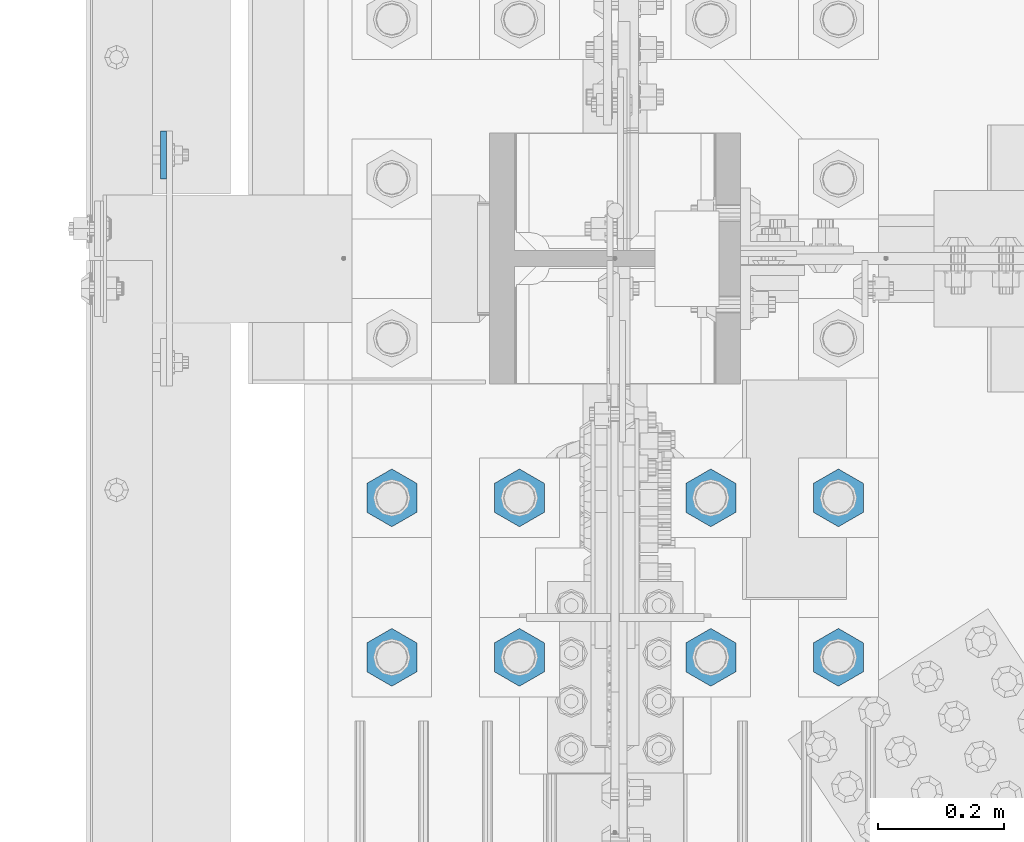
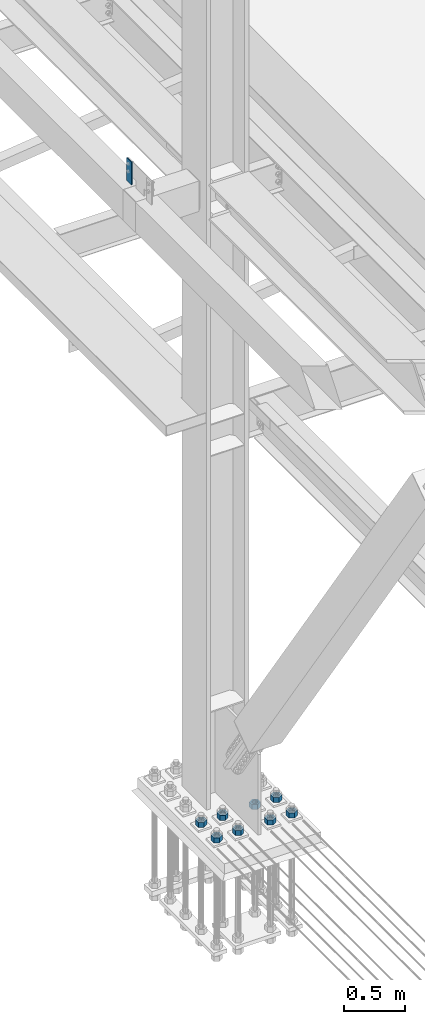
# One storey, part 1525 of 3843: 9 columns, 2 elements without a shape of their own.
"""IFC2X3 building model written with IfcOpenShell, lengths in millimetres."""

from ifc_helpers import new_model, si_unit, frame, origin_with_axes, place, context, subcontext, project, spatial, faceted_brep, material, type_object, element, aggregate, save


model = new_model("IFC2X3")

# Units and contexts
model_context = context("Model", 3, precision=1e-05, world=origin_with_axes())
body_context = subcontext(model_context, "Body", "Model", "MODEL_VIEW")
ifc_project = project(units=[si_unit("LENGTHUNIT", "METRE", prefix="MILLI"), si_unit("AREAUNIT", "SQUARE_METRE"), si_unit("VOLUMEUNIT", "CUBIC_METRE"), si_unit("MASSUNIT", "GRAM", prefix="KILO"), si_unit("TIMEUNIT", "SECOND"), si_unit("PLANEANGLEUNIT", "RADIAN"), si_unit("SOLIDANGLEUNIT", "STERADIAN"), si_unit("THERMODYNAMICTEMPERATUREUNIT", "DEGREE_CELSIUS"), si_unit("LUMINOUSINTENSITYUNIT", "LUMEN")], contexts=[model_context])

# Site, building, storey
site_placement = place(None, origin_with_axes())
site = spatial("IfcSite", under=ifc_project, at=site_placement, CompositionType="ELEMENT")
building_placement = place(site_placement, origin_with_axes())
building = spatial("IfcBuilding", under=site, at=building_placement, Name="Undefined", CompositionType="ELEMENT")
storey_placement = place(building_placement, origin_with_axes())
storey = spatial("IfcBuildingStorey", under=building, at=storey_placement, Name="Undefined", CompositionType="ELEMENT", Elevation=0.0)

# Assembly, column
assembly_1_placement = place(storey_placement, origin_with_axes())
assembly_1 = element("IfcElementAssembly", 1, at=assembly_1_placement, inside=storey, Name="GIRT", AssemblyPlace="NOTDEFINED", PredefinedType="RIGID_FRAME")
ifc_material = material(Name="STEEL/A572-50")
column_type_1 = type_object("IfcColumnType", PredefinedType="NOTDEFINED")
column_1_placement = place(assembly_1_placement, frame((35856.8625, 59080.4, 36404.55), z_axis=(0.0, 1.0, 0.0), x_axis=(0.0, 0.0, 1.0)))
column_1 = element("IfcColumn", 2, at=column_1_placement, type_object=column_type_1, material=ifc_material, Name="PLATE", context=body_context, shape_type="Brep", body=[
    faceted_brep([(0.0, 4.76250000000073, -38.0999999999985), (0.0, 4.76250000000073, 38.0999999999985), (228.599999999999, 4.76249999999709, 38.1000000000058), (228.599999999999, 4.76249999999709, -38.1000000000058), (0.0, -4.76250000000073, 38.0999999999985), (228.599999999999, -4.76249999999709, 38.1000000000058), (0.0, -4.76250000000073, -38.0999999999985), (228.599999999999, -4.76249999999709, -38.1000000000058)], [[[0, 1, 2, 3]], [[1, 4, 5, 2]], [[4, 6, 7, 5]], [[6, 0, 3, 7]], [[5, 7, 3, 2]], [[6, 4, 1, 0]]]),
])
aggregate(assembly_1, [column_1])

# Assembly, columns
assembly_2_placement = place(storey_placement, origin_with_axes())
assembly_2 = element("IfcElementAssembly", 3, at=assembly_2_placement, inside=storey, Name="TEMPLATE", AssemblyPlace="NOTDEFINED", PredefinedType="RIGID_FRAME")
column_type_2 = type_object("IfcColumnType", Name="2_HEAVY_HEX_NUT", PredefinedType="NOTDEFINED")
column_2_placement = place(assembly_2_placement, frame((36931.6, 58280.3, 30232.35), z_axis=(1.0, 0.0, 0.0), x_axis=(0.0, 0.0, -1.0)))
column_2 = element("IfcColumn", 4, at=column_2_placement, type_object=column_type_2, material=ifc_material, Name="NUT", ObjectType="2_HEAVY_HEX_NUT", context=body_context, shape_type="Brep", body=[
    faceted_brep([(0.0, -46.0369987487793, 0.0), (0.0, -23.0184993743896, -39.869213104248), (50.7999999999993, -23.0184993743896, -39.869213104248), (50.7999999999993, -46.0369987487793, 0.0), (0.0, 23.0184993743896, -39.869213104248), (50.7999999999993, 23.0184993743896, -39.869213104248), (0.0, 46.0369987487793, 0.0), (50.7999999999993, 46.0369987487793, 0.0), (0.0, 23.0184993743896, 39.869213104248), (50.7999999999993, 23.0184993743896, 39.869213104248), (0.0, -23.0184993743896, 39.869213104248), (50.7999999999993, -23.0184993743896, 39.869213104248), (0.0, 0.0, 26.1940002441406), (0.0, 11.3650617044477, 23.5999013092805), (50.7999999999993, 11.3650617044477, 23.5999013092805), (50.7999999999993, 0.0, 26.1940002441406), (0.0, 20.4791109456419, 16.3316083006721), (50.7999999999993, 20.4791109456419, 16.3316083006721), (0.0, 25.5370200498292, 5.82867859874386), (50.7999999999993, 25.5370200498292, 5.82867859874386), (0.0, 25.5370200498292, -5.82867859874386), (50.7999999999993, 25.5370200498292, -5.82867859874386), (0.0, 20.4791109456419, -16.3316083006721), (50.7999999999993, 20.4791109456419, -16.3316083006721), (0.0, 11.3650617044477, -23.5999013092805), (50.7999999999993, 11.3650617044477, -23.5999013092805), (0.0, 0.0, -26.1940002441406), (50.7999999999993, 0.0, -26.1940002441406), (0.0, -11.3650617044477, -23.5999013092805), (50.7999999999993, -11.3650617044477, -23.5999013092805), (0.0, -20.4791109456419, -16.3316083006721), (50.7999999999993, -20.4791109456419, -16.3316083006721), (0.0, -25.5370200498292, -5.82867859874386), (50.7999999999993, -25.5370200498292, -5.82867859874386), (0.0, -25.5370200498292, 5.82867859874386), (50.7999999999993, -25.5370200498292, 5.82867859874386), (0.0, -20.4791109456419, 16.3316083006721), (50.7999999999993, -20.4791109456419, 16.3316083006721), (0.0, -11.3650617044477, 23.5999013092805), (50.7999999999993, -11.3650617044477, 23.5999013092805)], [[[0, 1, 2, 3]], [[1, 4, 5, 2]], [[4, 6, 7, 5]], [[6, 8, 9, 7]], [[8, 10, 11, 9]], [[10, 0, 3, 11]], [[12, 13, 14, 15]], [[13, 16, 17, 14]], [[16, 18, 19, 17]], [[18, 20, 21, 19]], [[20, 22, 23, 21]], [[22, 24, 25, 23]], [[24, 26, 27, 25]], [[26, 28, 29, 27]], [[28, 30, 31, 29]], [[30, 32, 33, 31]], [[32, 34, 35, 33]], [[34, 36, 37, 35]], [[36, 38, 39, 37]], [[38, 12, 15, 39]], [[5, 7, 9, 11, 3, 2], [17, 19, 21, 23, 25, 27, 29, 31, 33, 35, 37, 39, 15, 14]], [[10, 8, 6, 4, 1, 0], [38, 36, 34, 32, 30, 28, 26, 24, 22, 20, 18, 16, 13, 12]]]),
])
column_3_placement = place(assembly_2_placement, frame((36931.6, 58534.3, 30232.35), z_axis=(1.0, 0.0, 0.0), x_axis=(0.0, 0.0, -1.0)))
column_3 = element("IfcColumn", 5, at=column_3_placement, type_object=column_type_2, material=ifc_material, Name="NUT", ObjectType="2_HEAVY_HEX_NUT", context=body_context, shape_type="Brep", body=[
    faceted_brep([(0.0, -46.0369987487793, 0.0), (0.0, -23.0184993743896, -39.869213104248), (50.7999999999993, -23.0184993743896, -39.869213104248), (50.7999999999993, -46.0369987487793, 0.0), (0.0, 23.0184993743896, -39.869213104248), (50.7999999999993, 23.0184993743896, -39.869213104248), (0.0, 46.0369987487793, 0.0), (50.7999999999993, 46.0369987487793, 0.0), (0.0, 23.0184993743896, 39.869213104248), (50.7999999999993, 23.0184993743896, 39.869213104248), (0.0, -23.0184993743896, 39.869213104248), (50.7999999999993, -23.0184993743896, 39.869213104248), (0.0, 0.0, 26.1940002441406), (0.0, 11.3650617044477, 23.5999013092805), (50.7999999999993, 11.3650617044477, 23.5999013092805), (50.7999999999993, 0.0, 26.1940002441406), (0.0, 20.4791109456419, 16.3316083006721), (50.7999999999993, 20.4791109456419, 16.3316083006721), (0.0, 25.5370200498292, 5.82867859874386), (50.7999999999993, 25.5370200498292, 5.82867859874386), (0.0, 25.5370200498292, -5.82867859874386), (50.7999999999993, 25.5370200498292, -5.82867859874386), (0.0, 20.4791109456419, -16.3316083006721), (50.7999999999993, 20.4791109456419, -16.3316083006721), (0.0, 11.3650617044477, -23.5999013092805), (50.7999999999993, 11.3650617044477, -23.5999013092805), (0.0, 0.0, -26.1940002441406), (50.7999999999993, 0.0, -26.1940002441406), (0.0, -11.3650617044477, -23.5999013092805), (50.7999999999993, -11.3650617044477, -23.5999013092805), (0.0, -20.4791109456419, -16.3316083006721), (50.7999999999993, -20.4791109456419, -16.3316083006721), (0.0, -25.5370200498292, -5.82867859874386), (50.7999999999993, -25.5370200498292, -5.82867859874386), (0.0, -25.5370200498292, 5.82867859874386), (50.7999999999993, -25.5370200498292, 5.82867859874386), (0.0, -20.4791109456419, 16.3316083006721), (50.7999999999993, -20.4791109456419, 16.3316083006721), (0.0, -11.3650617044477, 23.5999013092805), (50.7999999999993, -11.3650617044477, 23.5999013092805)], [[[0, 1, 2, 3]], [[1, 4, 5, 2]], [[4, 6, 7, 5]], [[6, 8, 9, 7]], [[8, 10, 11, 9]], [[10, 0, 3, 11]], [[12, 13, 14, 15]], [[13, 16, 17, 14]], [[16, 18, 19, 17]], [[18, 20, 21, 19]], [[20, 22, 23, 21]], [[22, 24, 25, 23]], [[24, 26, 27, 25]], [[26, 28, 29, 27]], [[28, 30, 31, 29]], [[30, 32, 33, 31]], [[32, 34, 35, 33]], [[34, 36, 37, 35]], [[36, 38, 39, 37]], [[38, 12, 15, 39]], [[5, 7, 9, 11, 3, 2], [17, 19, 21, 23, 25, 27, 29, 31, 33, 35, 37, 39, 15, 14]], [[10, 8, 6, 4, 1, 0], [38, 36, 34, 32, 30, 28, 26, 24, 22, 20, 18, 16, 13, 12]]]),
])
column_4_placement = place(assembly_2_placement, frame((36728.4, 58280.3, 30232.35), z_axis=(1.0, 0.0, 0.0), x_axis=(0.0, 0.0, -1.0)))
column_4 = element("IfcColumn", 6, at=column_4_placement, type_object=column_type_2, material=ifc_material, Name="NUT", ObjectType="2_HEAVY_HEX_NUT", context=body_context, shape_type="Brep", body=[
    faceted_brep([(0.0, -46.0369987487793, 0.0), (0.0, -23.0184993743896, -39.869213104248), (50.7999999999993, -23.0184993743896, -39.869213104248), (50.7999999999993, -46.0369987487793, 0.0), (0.0, 23.0184993743896, -39.869213104248), (50.7999999999993, 23.0184993743896, -39.869213104248), (0.0, 46.0369987487793, 0.0), (50.7999999999993, 46.0369987487793, 0.0), (0.0, 23.0184993743896, 39.869213104248), (50.7999999999993, 23.0184993743896, 39.869213104248), (0.0, -23.0184993743896, 39.869213104248), (50.7999999999993, -23.0184993743896, 39.869213104248), (0.0, 0.0, 26.1940002441406), (0.0, 11.3650617044477, 23.5999013092805), (50.7999999999993, 11.3650617044477, 23.5999013092805), (50.7999999999993, 0.0, 26.1940002441406), (0.0, 20.4791109456419, 16.3316083006721), (50.7999999999993, 20.4791109456419, 16.3316083006721), (0.0, 25.5370200498292, 5.82867859874386), (50.7999999999993, 25.5370200498292, 5.82867859874386), (0.0, 25.5370200498292, -5.82867859874386), (50.7999999999993, 25.5370200498292, -5.82867859874386), (0.0, 20.4791109456419, -16.3316083006721), (50.7999999999993, 20.4791109456419, -16.3316083006721), (0.0, 11.3650617044477, -23.5999013092805), (50.7999999999993, 11.3650617044477, -23.5999013092805), (0.0, 0.0, -26.1940002441406), (50.7999999999993, 0.0, -26.1940002441406), (0.0, -11.3650617044477, -23.5999013092805), (50.7999999999993, -11.3650617044477, -23.5999013092805), (0.0, -20.4791109456419, -16.3316083006721), (50.7999999999993, -20.4791109456419, -16.3316083006721), (0.0, -25.5370200498292, -5.82867859874386), (50.7999999999993, -25.5370200498292, -5.82867859874386), (0.0, -25.5370200498292, 5.82867859874386), (50.7999999999993, -25.5370200498292, 5.82867859874386), (0.0, -20.4791109456419, 16.3316083006721), (50.7999999999993, -20.4791109456419, 16.3316083006721), (0.0, -11.3650617044477, 23.5999013092805), (50.7999999999993, -11.3650617044477, 23.5999013092805)], [[[0, 1, 2, 3]], [[1, 4, 5, 2]], [[4, 6, 7, 5]], [[6, 8, 9, 7]], [[8, 10, 11, 9]], [[10, 0, 3, 11]], [[12, 13, 14, 15]], [[13, 16, 17, 14]], [[16, 18, 19, 17]], [[18, 20, 21, 19]], [[20, 22, 23, 21]], [[22, 24, 25, 23]], [[24, 26, 27, 25]], [[26, 28, 29, 27]], [[28, 30, 31, 29]], [[30, 32, 33, 31]], [[32, 34, 35, 33]], [[34, 36, 37, 35]], [[36, 38, 39, 37]], [[38, 12, 15, 39]], [[5, 7, 9, 11, 3, 2], [17, 19, 21, 23, 25, 27, 29, 31, 33, 35, 37, 39, 15, 14]], [[10, 8, 6, 4, 1, 0], [38, 36, 34, 32, 30, 28, 26, 24, 22, 20, 18, 16, 13, 12]]]),
])
column_5_placement = place(assembly_2_placement, frame((36728.4, 58534.3, 30232.35), z_axis=(1.0, 0.0, 0.0), x_axis=(0.0, 0.0, -1.0)))
column_5 = element("IfcColumn", 7, at=column_5_placement, type_object=column_type_2, material=ifc_material, Name="NUT", ObjectType="2_HEAVY_HEX_NUT", context=body_context, shape_type="Brep", body=[
    faceted_brep([(0.0, -46.0369987487793, 0.0), (0.0, -23.0184993743896, -39.869213104248), (50.7999999999993, -23.0184993743896, -39.869213104248), (50.7999999999993, -46.0369987487793, 0.0), (0.0, 23.0184993743896, -39.869213104248), (50.7999999999993, 23.0184993743896, -39.869213104248), (0.0, 46.0369987487793, 0.0), (50.7999999999993, 46.0369987487793, 0.0), (0.0, 23.0184993743896, 39.869213104248), (50.7999999999993, 23.0184993743896, 39.869213104248), (0.0, -23.0184993743896, 39.869213104248), (50.7999999999993, -23.0184993743896, 39.869213104248), (0.0, 0.0, 26.1940002441406), (0.0, 11.3650617044477, 23.5999013092805), (50.7999999999993, 11.3650617044477, 23.5999013092805), (50.7999999999993, 0.0, 26.1940002441406), (0.0, 20.4791109456419, 16.3316083006721), (50.7999999999993, 20.4791109456419, 16.3316083006721), (0.0, 25.5370200498292, 5.82867859874386), (50.7999999999993, 25.5370200498292, 5.82867859874386), (0.0, 25.5370200498292, -5.82867859874386), (50.7999999999993, 25.5370200498292, -5.82867859874386), (0.0, 20.4791109456419, -16.3316083006721), (50.7999999999993, 20.4791109456419, -16.3316083006721), (0.0, 11.3650617044477, -23.5999013092805), (50.7999999999993, 11.3650617044477, -23.5999013092805), (0.0, 0.0, -26.1940002441406), (50.7999999999993, 0.0, -26.1940002441406), (0.0, -11.3650617044477, -23.5999013092805), (50.7999999999993, -11.3650617044477, -23.5999013092805), (0.0, -20.4791109456419, -16.3316083006721), (50.7999999999993, -20.4791109456419, -16.3316083006721), (0.0, -25.5370200498292, -5.82867859874386), (50.7999999999993, -25.5370200498292, -5.82867859874386), (0.0, -25.5370200498292, 5.82867859874386), (50.7999999999993, -25.5370200498292, 5.82867859874386), (0.0, -20.4791109456419, 16.3316083006721), (50.7999999999993, -20.4791109456419, 16.3316083006721), (0.0, -11.3650617044477, 23.5999013092805), (50.7999999999993, -11.3650617044477, 23.5999013092805)], [[[0, 1, 2, 3]], [[1, 4, 5, 2]], [[4, 6, 7, 5]], [[6, 8, 9, 7]], [[8, 10, 11, 9]], [[10, 0, 3, 11]], [[12, 13, 14, 15]], [[13, 16, 17, 14]], [[16, 18, 19, 17]], [[18, 20, 21, 19]], [[20, 22, 23, 21]], [[22, 24, 25, 23]], [[24, 26, 27, 25]], [[26, 28, 29, 27]], [[28, 30, 31, 29]], [[30, 32, 33, 31]], [[32, 34, 35, 33]], [[34, 36, 37, 35]], [[36, 38, 39, 37]], [[38, 12, 15, 39]], [[5, 7, 9, 11, 3, 2], [17, 19, 21, 23, 25, 27, 29, 31, 33, 35, 37, 39, 15, 14]], [[10, 8, 6, 4, 1, 0], [38, 36, 34, 32, 30, 28, 26, 24, 22, 20, 18, 16, 13, 12]]]),
])
column_6_placement = place(assembly_2_placement, frame((36423.6, 58280.3, 30232.35), z_axis=(1.0, 0.0, 0.0), x_axis=(0.0, 0.0, -1.0)))
column_6 = element("IfcColumn", 8, at=column_6_placement, type_object=column_type_2, material=ifc_material, Name="NUT", ObjectType="2_HEAVY_HEX_NUT", context=body_context, shape_type="Brep", body=[
    faceted_brep([(0.0, -46.0369987487793, 0.0), (0.0, -23.0184993743896, -39.869213104248), (50.7999999999993, -23.0184993743896, -39.869213104248), (50.7999999999993, -46.0369987487793, 0.0), (0.0, 23.0184993743896, -39.869213104248), (50.7999999999993, 23.0184993743896, -39.869213104248), (0.0, 46.0369987487793, 0.0), (50.7999999999993, 46.0369987487793, 0.0), (0.0, 23.0184993743896, 39.869213104248), (50.7999999999993, 23.0184993743896, 39.869213104248), (0.0, -23.0184993743896, 39.869213104248), (50.7999999999993, -23.0184993743896, 39.869213104248), (0.0, 0.0, 26.1940002441406), (0.0, 11.3650617044477, 23.5999013092805), (50.7999999999993, 11.3650617044477, 23.5999013092805), (50.7999999999993, 0.0, 26.1940002441406), (0.0, 20.4791109456419, 16.3316083006721), (50.7999999999993, 20.4791109456419, 16.3316083006721), (0.0, 25.5370200498292, 5.82867859874386), (50.7999999999993, 25.5370200498292, 5.82867859874386), (0.0, 25.5370200498292, -5.82867859874386), (50.7999999999993, 25.5370200498292, -5.82867859874386), (0.0, 20.4791109456419, -16.3316083006721), (50.7999999999993, 20.4791109456419, -16.3316083006721), (0.0, 11.3650617044477, -23.5999013092805), (50.7999999999993, 11.3650617044477, -23.5999013092805), (0.0, 0.0, -26.1940002441406), (50.7999999999993, 0.0, -26.1940002441406), (0.0, -11.3650617044477, -23.5999013092805), (50.7999999999993, -11.3650617044477, -23.5999013092805), (0.0, -20.4791109456419, -16.3316083006721), (50.7999999999993, -20.4791109456419, -16.3316083006721), (0.0, -25.5370200498292, -5.82867859874386), (50.7999999999993, -25.5370200498292, -5.82867859874386), (0.0, -25.5370200498292, 5.82867859874386), (50.7999999999993, -25.5370200498292, 5.82867859874386), (0.0, -20.4791109456419, 16.3316083006721), (50.7999999999993, -20.4791109456419, 16.3316083006721), (0.0, -11.3650617044477, 23.5999013092805), (50.7999999999993, -11.3650617044477, 23.5999013092805)], [[[0, 1, 2, 3]], [[1, 4, 5, 2]], [[4, 6, 7, 5]], [[6, 8, 9, 7]], [[8, 10, 11, 9]], [[10, 0, 3, 11]], [[12, 13, 14, 15]], [[13, 16, 17, 14]], [[16, 18, 19, 17]], [[18, 20, 21, 19]], [[20, 22, 23, 21]], [[22, 24, 25, 23]], [[24, 26, 27, 25]], [[26, 28, 29, 27]], [[28, 30, 31, 29]], [[30, 32, 33, 31]], [[32, 34, 35, 33]], [[34, 36, 37, 35]], [[36, 38, 39, 37]], [[38, 12, 15, 39]], [[5, 7, 9, 11, 3, 2], [17, 19, 21, 23, 25, 27, 29, 31, 33, 35, 37, 39, 15, 14]], [[10, 8, 6, 4, 1, 0], [38, 36, 34, 32, 30, 28, 26, 24, 22, 20, 18, 16, 13, 12]]]),
])
column_7_placement = place(assembly_2_placement, frame((36423.6, 58534.3, 30232.35), z_axis=(1.0, 0.0, 0.0), x_axis=(0.0, 0.0, -1.0)))
column_7 = element("IfcColumn", 9, at=column_7_placement, type_object=column_type_2, material=ifc_material, Name="NUT", ObjectType="2_HEAVY_HEX_NUT", context=body_context, shape_type="Brep", body=[
    faceted_brep([(0.0, -46.0369987487793, 0.0), (0.0, -23.0184993743896, -39.869213104248), (50.7999999999993, -23.0184993743896, -39.869213104248), (50.7999999999993, -46.0369987487793, 0.0), (0.0, 23.0184993743896, -39.869213104248), (50.7999999999993, 23.0184993743896, -39.869213104248), (0.0, 46.0369987487793, 0.0), (50.7999999999993, 46.0369987487793, 0.0), (0.0, 23.0184993743896, 39.869213104248), (50.7999999999993, 23.0184993743896, 39.869213104248), (0.0, -23.0184993743896, 39.869213104248), (50.7999999999993, -23.0184993743896, 39.869213104248), (0.0, 0.0, 26.1940002441406), (0.0, 11.3650617044477, 23.5999013092805), (50.7999999999993, 11.3650617044477, 23.5999013092805), (50.7999999999993, 0.0, 26.1940002441406), (0.0, 20.4791109456419, 16.3316083006721), (50.7999999999993, 20.4791109456419, 16.3316083006721), (0.0, 25.5370200498292, 5.82867859874386), (50.7999999999993, 25.5370200498292, 5.82867859874386), (0.0, 25.5370200498292, -5.82867859874386), (50.7999999999993, 25.5370200498292, -5.82867859874386), (0.0, 20.4791109456419, -16.3316083006721), (50.7999999999993, 20.4791109456419, -16.3316083006721), (0.0, 11.3650617044477, -23.5999013092805), (50.7999999999993, 11.3650617044477, -23.5999013092805), (0.0, 0.0, -26.1940002441406), (50.7999999999993, 0.0, -26.1940002441406), (0.0, -11.3650617044477, -23.5999013092805), (50.7999999999993, -11.3650617044477, -23.5999013092805), (0.0, -20.4791109456419, -16.3316083006721), (50.7999999999993, -20.4791109456419, -16.3316083006721), (0.0, -25.5370200498292, -5.82867859874386), (50.7999999999993, -25.5370200498292, -5.82867859874386), (0.0, -25.5370200498292, 5.82867859874386), (50.7999999999993, -25.5370200498292, 5.82867859874386), (0.0, -20.4791109456419, 16.3316083006721), (50.7999999999993, -20.4791109456419, 16.3316083006721), (0.0, -11.3650617044477, 23.5999013092805), (50.7999999999993, -11.3650617044477, 23.5999013092805)], [[[0, 1, 2, 3]], [[1, 4, 5, 2]], [[4, 6, 7, 5]], [[6, 8, 9, 7]], [[8, 10, 11, 9]], [[10, 0, 3, 11]], [[12, 13, 14, 15]], [[13, 16, 17, 14]], [[16, 18, 19, 17]], [[18, 20, 21, 19]], [[20, 22, 23, 21]], [[22, 24, 25, 23]], [[24, 26, 27, 25]], [[26, 28, 29, 27]], [[28, 30, 31, 29]], [[30, 32, 33, 31]], [[32, 34, 35, 33]], [[34, 36, 37, 35]], [[36, 38, 39, 37]], [[38, 12, 15, 39]], [[5, 7, 9, 11, 3, 2], [17, 19, 21, 23, 25, 27, 29, 31, 33, 35, 37, 39, 15, 14]], [[10, 8, 6, 4, 1, 0], [38, 36, 34, 32, 30, 28, 26, 24, 22, 20, 18, 16, 13, 12]]]),
])
column_8_placement = place(assembly_2_placement, frame((36220.4, 58280.3, 30232.35), z_axis=(1.0, 0.0, 0.0), x_axis=(0.0, 0.0, -1.0)))
column_8 = element("IfcColumn", 10, at=column_8_placement, type_object=column_type_2, material=ifc_material, Name="NUT", ObjectType="2_HEAVY_HEX_NUT", context=body_context, shape_type="Brep", body=[
    faceted_brep([(0.0, -46.0369987487793, 0.0), (0.0, -23.0184993743896, -39.869213104248), (50.7999999999993, -23.0184993743896, -39.869213104248), (50.7999999999993, -46.0369987487793, 0.0), (0.0, 23.0184993743896, -39.869213104248), (50.7999999999993, 23.0184993743896, -39.869213104248), (0.0, 46.0369987487793, 0.0), (50.7999999999993, 46.0369987487793, 0.0), (0.0, 23.0184993743896, 39.869213104248), (50.7999999999993, 23.0184993743896, 39.869213104248), (0.0, -23.0184993743896, 39.869213104248), (50.7999999999993, -23.0184993743896, 39.869213104248), (0.0, 0.0, 26.1940002441406), (0.0, 11.3650617044477, 23.5999013092805), (50.7999999999993, 11.3650617044477, 23.5999013092805), (50.7999999999993, 0.0, 26.1940002441406), (0.0, 20.4791109456419, 16.3316083006721), (50.7999999999993, 20.4791109456419, 16.3316083006721), (0.0, 25.5370200498292, 5.82867859874386), (50.7999999999993, 25.5370200498292, 5.82867859874386), (0.0, 25.5370200498292, -5.82867859874386), (50.7999999999993, 25.5370200498292, -5.82867859874386), (0.0, 20.4791109456419, -16.3316083006721), (50.7999999999993, 20.4791109456419, -16.3316083006721), (0.0, 11.3650617044477, -23.5999013092805), (50.7999999999993, 11.3650617044477, -23.5999013092805), (0.0, 0.0, -26.1940002441406), (50.7999999999993, 0.0, -26.1940002441406), (0.0, -11.3650617044477, -23.5999013092805), (50.7999999999993, -11.3650617044477, -23.5999013092805), (0.0, -20.4791109456419, -16.3316083006721), (50.7999999999993, -20.4791109456419, -16.3316083006721), (0.0, -25.5370200498292, -5.82867859874386), (50.7999999999993, -25.5370200498292, -5.82867859874386), (0.0, -25.5370200498292, 5.82867859874386), (50.7999999999993, -25.5370200498292, 5.82867859874386), (0.0, -20.4791109456419, 16.3316083006721), (50.7999999999993, -20.4791109456419, 16.3316083006721), (0.0, -11.3650617044477, 23.5999013092805), (50.7999999999993, -11.3650617044477, 23.5999013092805)], [[[0, 1, 2, 3]], [[1, 4, 5, 2]], [[4, 6, 7, 5]], [[6, 8, 9, 7]], [[8, 10, 11, 9]], [[10, 0, 3, 11]], [[12, 13, 14, 15]], [[13, 16, 17, 14]], [[16, 18, 19, 17]], [[18, 20, 21, 19]], [[20, 22, 23, 21]], [[22, 24, 25, 23]], [[24, 26, 27, 25]], [[26, 28, 29, 27]], [[28, 30, 31, 29]], [[30, 32, 33, 31]], [[32, 34, 35, 33]], [[34, 36, 37, 35]], [[36, 38, 39, 37]], [[38, 12, 15, 39]], [[5, 7, 9, 11, 3, 2], [17, 19, 21, 23, 25, 27, 29, 31, 33, 35, 37, 39, 15, 14]], [[10, 8, 6, 4, 1, 0], [38, 36, 34, 32, 30, 28, 26, 24, 22, 20, 18, 16, 13, 12]]]),
])
column_9_placement = place(assembly_2_placement, frame((36220.4, 58534.3, 30232.35), z_axis=(1.0, 0.0, 0.0), x_axis=(0.0, 0.0, -1.0)))
column_9 = element("IfcColumn", 11, at=column_9_placement, type_object=column_type_2, material=ifc_material, Name="NUT", ObjectType="2_HEAVY_HEX_NUT", context=body_context, shape_type="Brep", body=[
    faceted_brep([(0.0, -46.0369987487793, 0.0), (0.0, -23.0184993743896, -39.869213104248), (50.7999999999993, -23.0184993743896, -39.869213104248), (50.7999999999993, -46.0369987487793, 0.0), (0.0, 23.0184993743896, -39.869213104248), (50.7999999999993, 23.0184993743896, -39.869213104248), (0.0, 46.0369987487793, 0.0), (50.7999999999993, 46.0369987487793, 0.0), (0.0, 23.0184993743896, 39.869213104248), (50.7999999999993, 23.0184993743896, 39.869213104248), (0.0, -23.0184993743896, 39.869213104248), (50.7999999999993, -23.0184993743896, 39.869213104248), (0.0, 0.0, 26.1940002441406), (0.0, 11.3650617044477, 23.5999013092805), (50.7999999999993, 11.3650617044477, 23.5999013092805), (50.7999999999993, 0.0, 26.1940002441406), (0.0, 20.4791109456419, 16.3316083006721), (50.7999999999993, 20.4791109456419, 16.3316083006721), (0.0, 25.5370200498292, 5.82867859874386), (50.7999999999993, 25.5370200498292, 5.82867859874386), (0.0, 25.5370200498292, -5.82867859874386), (50.7999999999993, 25.5370200498292, -5.82867859874386), (0.0, 20.4791109456419, -16.3316083006721), (50.7999999999993, 20.4791109456419, -16.3316083006721), (0.0, 11.3650617044477, -23.5999013092805), (50.7999999999993, 11.3650617044477, -23.5999013092805), (0.0, 0.0, -26.1940002441406), (50.7999999999993, 0.0, -26.1940002441406), (0.0, -11.3650617044477, -23.5999013092805), (50.7999999999993, -11.3650617044477, -23.5999013092805), (0.0, -20.4791109456419, -16.3316083006721), (50.7999999999993, -20.4791109456419, -16.3316083006721), (0.0, -25.5370200498292, -5.82867859874386), (50.7999999999993, -25.5370200498292, -5.82867859874386), (0.0, -25.5370200498292, 5.82867859874386), (50.7999999999993, -25.5370200498292, 5.82867859874386), (0.0, -20.4791109456419, 16.3316083006721), (50.7999999999993, -20.4791109456419, 16.3316083006721), (0.0, -11.3650617044477, 23.5999013092805), (50.7999999999993, -11.3650617044477, 23.5999013092805)], [[[0, 1, 2, 3]], [[1, 4, 5, 2]], [[4, 6, 7, 5]], [[6, 8, 9, 7]], [[8, 10, 11, 9]], [[10, 0, 3, 11]], [[12, 13, 14, 15]], [[13, 16, 17, 14]], [[16, 18, 19, 17]], [[18, 20, 21, 19]], [[20, 22, 23, 21]], [[22, 24, 25, 23]], [[24, 26, 27, 25]], [[26, 28, 29, 27]], [[28, 30, 31, 29]], [[30, 32, 33, 31]], [[32, 34, 35, 33]], [[34, 36, 37, 35]], [[36, 38, 39, 37]], [[38, 12, 15, 39]], [[5, 7, 9, 11, 3, 2], [17, 19, 21, 23, 25, 27, 29, 31, 33, 35, 37, 39, 15, 14]], [[10, 8, 6, 4, 1, 0], [38, 36, 34, 32, 30, 28, 26, 24, 22, 20, 18, 16, 13, 12]]]),
])
aggregate(assembly_2, [column_2, column_3, column_4, column_5, column_6, column_7, column_8, column_9])

save(model, "model.ifc")
